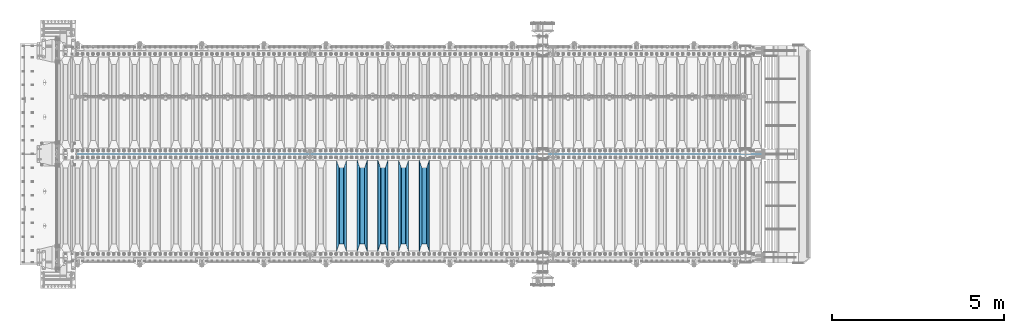
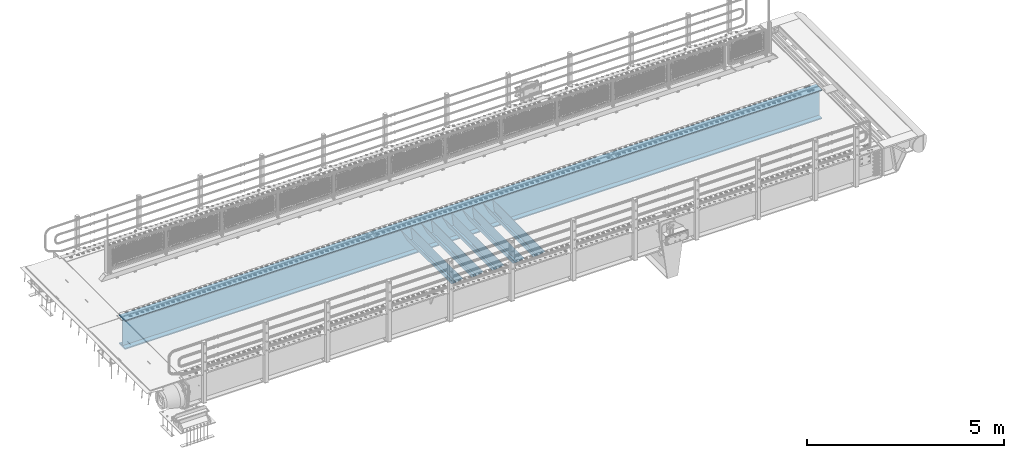
# One storey, part 119 of 242: 6 beams.
"""IFC2X3 building model written with IfcOpenShell, lengths in millimetres."""

from ifc_helpers import new_model, si_unit, frame, origin_with_axes, place, context, subcontext, project, spatial, faceted_brep, material, type_object, element, save


model = new_model("IFC2X3")

# Units and contexts
model_context = context("Model", 3, precision=1e-05, world=origin_with_axes())
body_context = subcontext(model_context, "Body", "Model", "MODEL_VIEW")
ifc_project = project(units=[si_unit("LENGTHUNIT", "METRE", prefix="MILLI"), si_unit("AREAUNIT", "SQUARE_METRE"), si_unit("VOLUMEUNIT", "CUBIC_METRE"), si_unit("MASSUNIT", "GRAM", prefix="KILO"), si_unit("TIMEUNIT", "SECOND"), si_unit("PLANEANGLEUNIT", "RADIAN"), si_unit("SOLIDANGLEUNIT", "STERADIAN"), si_unit("THERMODYNAMICTEMPERATUREUNIT", "DEGREE_CELSIUS"), si_unit("LUMINOUSINTENSITYUNIT", "LUMEN")], contexts=[model_context])

# Site, building, storey
site_placement = place(None, origin_with_axes())
site = spatial("IfcSite", under=ifc_project, at=site_placement, CompositionType="ELEMENT")
building_placement = place(site_placement, origin_with_axes())
building = spatial("IfcBuilding", under=site, at=building_placement, Name="Standard", CompositionType="ELEMENT")
storey_placement = place(building_placement, origin_with_axes())
storey = spatial("IfcBuildingStorey", under=building, at=storey_placement, Name="Undefined", CompositionType="ELEMENT", Elevation=0.0)

# Beams
ifc_material = material(Name="STEEL/S355N")
beam_type_1 = type_object("IfcBeamType", PredefinedType="NOTDEFINED")
beam_1_placement = place(storey_placement, frame((-31850.0, -23825.0, -115.0), z_axis=(0.0, 0.0, 1.0), x_axis=(0.0, 1.0, 0.0)))
element("IfcBeam", 1, at=beam_1_placement, inside=storey, type_object=beam_type_1, material=ifc_material, context=body_context, shape_type="Brep", body=[
    faceted_brep([(0.0, 150.0, 115.0), (0.0, 143.689999999999, 115.0), (2650.00000000297, 143.689999999999, 115.0), (2650.00000000297, 150.0, 115.0), (2650.00000000297, 142.059565218402, 110.000000003099), (2650.00000000297, 148.369565218403, 110.000000003099), (2441.90079219209, -80.1103600731112, -98.0992078077845), (2437.7588105432, -77.5672621345584, -102.241189456673), (2434.06523489747, -74.4080125315522, -105.934765102404), (2430.91086095089, -70.710272125576, -109.089139048974), (2428.37322971128, -66.5649389910068, -111.626770288588), (2426.51472138055, -62.0739139532889, -113.485278619323), (2425.38102192092, -57.3475956567672, -114.618978078955), (2424.99999999987, -52.5021667386536, -115.0), (2424.99999999987, 52.5021667386536, -115.0), (2425.38102192092, 57.3475956567672, -114.618978078955), (2426.51472138055, 62.0739139532889, -113.485278619323), (2428.37322971128, 66.5649389910068, -111.626770288588), (2430.91086095089, 70.710272125576, -109.089139048974), (2434.06523489747, 74.4080125315522, -105.934765102404), (2437.7588105432, 77.5672621345584, -102.241189456673), (2441.90079219209, 80.1103600731112, -98.0992078077846), (2446.38936140511, 81.9747917625791, -93.6106385947584), (2448.2494850041, 76.2713538057251, -91.7505149957729), (2444.62967112262, 74.76777986261, -95.3703288772456), (2441.28936334126, 72.7168944282894, -98.710636658607), (2438.31067330438, 70.1691124903846, -101.689326695487), (2435.76682334747, 67.1870637758839, -104.233176652398), (2433.72034654133, 63.8440531834895, -106.279653458539), (2432.22154950042, 60.222258798236, -107.778450499454), (2431.30727574265, 56.4107117849089, -108.692724257221), (2430.99999999987, 52.5031078186876, -109.0), (2430.99999999987, -52.5031078186876, -109.0), (2431.30727574265, -56.4107117849089, -108.692724257221), (2432.22154950042, -60.222258798236, -107.778450499454), (2433.72034654133, -63.8440531834895, -106.279653458539), (2435.76682334747, -67.1870637758839, -104.233176652398), (2438.31067330438, -70.1691124903846, -101.689326695487), (2441.28936334126, -72.7168944282894, -98.7106366586071), (2444.62967112262, -74.76777986261, -95.3703288772457), (2448.2494850041, -76.2713538057251, -91.7505149957729), (2650.00000000297, -142.059565218402, 110.000000003099), (2650.00000000297, -148.369565218403, 110.000000003099), (2446.38936140511, -81.9747917625791, -93.6106385947584), (2650.00000000297, -143.689999999999, 115.0), (2650.00000000297, -150.0, 115.0), (0.0, -143.689999999999, 115.0), (0.0, -150.0, 115.0), (0.0, -148.369565218261, 110.000000002669), (203.610638597427, -81.9747917625791, -93.6106385947584), (208.099207810454, -80.1103600731112, -98.0992078077845), (212.241189459342, -77.5672621345584, -102.241189456673), (215.934765105074, -74.4080125315522, -105.934765102404), (219.089139051644, -70.710272125576, -109.089139048974), (221.626770291256, -66.5649389910068, -111.626770288588), (223.485278621993, -62.0739139532889, -113.485278619323), (224.618978081624, -57.3475956567672, -114.618978078955), (225.00000000267, -52.5021667386536, -115.0), (225.00000000267, 52.5021667386536, -115.0), (224.618978081624, 57.3475956567672, -114.618978078955), (223.485278621993, 62.0739139532889, -113.485278619323), (221.626770291256, 66.5649389910068, -111.626770288588), (219.089139051644, 70.710272125576, -109.089139048974), (215.934765105074, 74.4080125315522, -105.934765102404), (212.241189459342, 77.5672621345584, -102.241189456673), (208.099207810454, 80.1103600731112, -98.0992078077846), (203.610638597427, 81.9747917625791, -93.6106385947584), (0.0, 148.369565218261, 110.000000002669), (0.0, 142.05956521826, 110.000000002669), (201.750514998443, 76.2713538057251, -91.7505149957729), (205.370328879915, 74.76777986261, -95.3703288772456), (208.710636661275, 72.7168944282894, -98.710636658607), (211.689326698157, 70.1691124903846, -101.689326695487), (214.233176655067, 67.1870637758839, -104.233176652398), (216.279653461206, 63.8440531834895, -106.279653458539), (217.778450502123, 60.222258798236, -107.778450499454), (218.69272425989, 56.4107117849089, -108.692724257221), (219.00000000267, 52.5031078186876, -109.0), (219.00000000267, -52.5031078186876, -109.0), (218.69272425989, -56.4107117849089, -108.692724257221), (217.778450502123, -60.222258798236, -107.778450499454), (216.279653461206, -63.8440531834895, -106.279653458539), (214.233176655067, -67.1870637758839, -104.233176652398), (211.689326698157, -70.1691124903846, -101.689326695487), (208.710636661275, -72.7168944282894, -98.7106366586071), (205.370328879915, -74.76777986261, -95.3703288772457), (201.750514998443, -76.2713538057251, -91.7505149957729), (0.0, -142.05956521826, 110.000000002669)], [[[0, 1, 2, 3]], [[3, 2, 4, 5]], [[6, 7, 8, 9, 10, 11, 12, 13, 14, 15, 16, 17, 18, 19, 20, 21, 22, 5, 4, 23, 24, 25, 26, 27, 28, 29, 30, 31, 32, 33, 34, 35, 36, 37, 38, 39, 40, 41, 42, 43]], [[44, 45, 42, 41]], [[46, 47, 45, 44]], [[43, 42, 45, 47, 48, 49]], [[6, 43, 49, 50]], [[7, 6, 50, 51]], [[8, 7, 51, 52]], [[9, 8, 52, 53]], [[10, 9, 53, 54]], [[11, 10, 54, 55]], [[12, 11, 55, 56]], [[13, 12, 56, 57]], [[14, 13, 57, 58]], [[15, 14, 58, 59]], [[16, 15, 59, 60]], [[17, 16, 60, 61]], [[18, 17, 61, 62]], [[19, 18, 62, 63]], [[20, 19, 63, 64]], [[21, 20, 64, 65]], [[22, 21, 65, 66]], [[0, 3, 5, 22, 66, 67]], [[1, 0, 67, 68]], [[23, 4, 2, 1, 68, 69]], [[24, 23, 69, 70]], [[25, 24, 70, 71]], [[26, 25, 71, 72]], [[27, 26, 72, 73]], [[28, 27, 73, 74]], [[29, 28, 74, 75]], [[30, 29, 75, 76]], [[31, 30, 76, 77]], [[32, 31, 77, 78]], [[33, 32, 78, 79]], [[34, 33, 79, 80]], [[35, 34, 80, 81]], [[36, 35, 81, 82]], [[37, 36, 82, 83]], [[38, 37, 83, 84]], [[39, 38, 84, 85]], [[40, 39, 85, 86]], [[46, 44, 41, 40, 86, 87]], [[47, 46, 87, 48]], [[86, 85, 84, 83, 82, 81, 80, 79, 78, 77, 76, 75, 74, 73, 72, 71, 70, 69, 68, 67, 66, 65, 64, 63, 62, 61, 60, 59, 58, 57, 56, 55, 54, 53, 52, 51, 50, 49, 48, 87]]]),
])
beam_2_placement = place(storey_placement, frame((-32450.0, -23825.0, -115.0), z_axis=(0.0, 0.0, 1.0), x_axis=(0.0, 1.0, 0.0)))
element("IfcBeam", 2, at=beam_2_placement, inside=storey, type_object=beam_type_1, material=ifc_material, context=body_context, shape_type="Brep", body=[
    faceted_brep([(0.0, 150.0, 115.0), (0.0, 143.689999999999, 115.0), (2650.00000000297, 143.689999999999, 115.0), (2650.00000000297, 150.0, 115.0), (2650.00000000297, 142.059565218402, 110.000000003099), (2650.00000000297, 148.369565218403, 110.000000003099), (2441.90079219209, -80.1103600731112, -98.0992078077845), (2437.7588105432, -77.5672621345584, -102.241189456673), (2434.06523489747, -74.4080125315522, -105.934765102404), (2430.91086095089, -70.710272125576, -109.089139048974), (2428.37322971128, -66.5649389910068, -111.626770288588), (2426.51472138055, -62.0739139532889, -113.485278619323), (2425.38102192092, -57.3475956567672, -114.618978078955), (2424.99999999987, -52.5021667386536, -115.0), (2424.99999999987, 52.5021667386536, -115.0), (2425.38102192092, 57.3475956567672, -114.618978078955), (2426.51472138055, 62.0739139532889, -113.485278619323), (2428.37322971128, 66.5649389910068, -111.626770288588), (2430.91086095089, 70.710272125576, -109.089139048974), (2434.06523489747, 74.4080125315522, -105.934765102404), (2437.7588105432, 77.5672621345584, -102.241189456673), (2441.90079219209, 80.1103600731112, -98.0992078077846), (2446.38936140511, 81.9747917625791, -93.6106385947584), (2448.2494850041, 76.2713538057251, -91.7505149957729), (2444.62967112262, 74.76777986261, -95.3703288772456), (2441.28936334126, 72.7168944282894, -98.710636658607), (2438.31067330438, 70.1691124903846, -101.689326695487), (2435.76682334747, 67.1870637758839, -104.233176652398), (2433.72034654133, 63.8440531834895, -106.279653458539), (2432.22154950042, 60.222258798236, -107.778450499454), (2431.30727574265, 56.4107117849089, -108.692724257221), (2430.99999999987, 52.5031078186876, -109.0), (2430.99999999987, -52.5031078186876, -109.0), (2431.30727574265, -56.4107117849089, -108.692724257221), (2432.22154950042, -60.222258798236, -107.778450499454), (2433.72034654133, -63.8440531834895, -106.279653458539), (2435.76682334747, -67.1870637758839, -104.233176652398), (2438.31067330438, -70.1691124903846, -101.689326695487), (2441.28936334126, -72.7168944282894, -98.7106366586071), (2444.62967112262, -74.76777986261, -95.3703288772457), (2448.2494850041, -76.2713538057251, -91.7505149957729), (2650.00000000297, -142.059565218402, 110.000000003099), (2650.00000000297, -148.369565218403, 110.000000003099), (2446.38936140511, -81.9747917625791, -93.6106385947584), (2650.00000000297, -143.689999999999, 115.0), (2650.00000000297, -150.0, 115.0), (0.0, -143.689999999999, 115.0), (0.0, -150.0, 115.0), (0.0, -148.369565218261, 110.000000002669), (203.610638597427, -81.9747917625791, -93.6106385947584), (208.099207810454, -80.1103600731112, -98.0992078077845), (212.241189459342, -77.5672621345584, -102.241189456673), (215.934765105074, -74.4080125315522, -105.934765102404), (219.089139051644, -70.710272125576, -109.089139048974), (221.626770291256, -66.5649389910068, -111.626770288588), (223.485278621993, -62.0739139532889, -113.485278619323), (224.618978081624, -57.3475956567672, -114.618978078955), (225.00000000267, -52.5021667386536, -115.0), (225.00000000267, 52.5021667386536, -115.0), (224.618978081624, 57.3475956567672, -114.618978078955), (223.485278621993, 62.0739139532889, -113.485278619323), (221.626770291256, 66.5649389910068, -111.626770288588), (219.089139051644, 70.710272125576, -109.089139048974), (215.934765105074, 74.4080125315522, -105.934765102404), (212.241189459342, 77.5672621345584, -102.241189456673), (208.099207810454, 80.1103600731112, -98.0992078077846), (203.610638597427, 81.9747917625791, -93.6106385947584), (0.0, 148.369565218261, 110.000000002669), (0.0, 142.05956521826, 110.000000002669), (201.750514998443, 76.2713538057251, -91.7505149957729), (205.370328879915, 74.76777986261, -95.3703288772456), (208.710636661275, 72.7168944282894, -98.710636658607), (211.689326698157, 70.1691124903846, -101.689326695487), (214.233176655067, 67.1870637758839, -104.233176652398), (216.279653461206, 63.8440531834895, -106.279653458539), (217.778450502123, 60.222258798236, -107.778450499454), (218.69272425989, 56.4107117849089, -108.692724257221), (219.00000000267, 52.5031078186876, -109.0), (219.00000000267, -52.5031078186876, -109.0), (218.69272425989, -56.4107117849089, -108.692724257221), (217.778450502123, -60.222258798236, -107.778450499454), (216.279653461206, -63.8440531834895, -106.279653458539), (214.233176655067, -67.1870637758839, -104.233176652398), (211.689326698157, -70.1691124903846, -101.689326695487), (208.710636661275, -72.7168944282894, -98.7106366586071), (205.370328879915, -74.76777986261, -95.3703288772457), (201.750514998443, -76.2713538057251, -91.7505149957729), (0.0, -142.05956521826, 110.000000002669)], [[[0, 1, 2, 3]], [[3, 2, 4, 5]], [[6, 7, 8, 9, 10, 11, 12, 13, 14, 15, 16, 17, 18, 19, 20, 21, 22, 5, 4, 23, 24, 25, 26, 27, 28, 29, 30, 31, 32, 33, 34, 35, 36, 37, 38, 39, 40, 41, 42, 43]], [[44, 45, 42, 41]], [[46, 47, 45, 44]], [[43, 42, 45, 47, 48, 49]], [[6, 43, 49, 50]], [[7, 6, 50, 51]], [[8, 7, 51, 52]], [[9, 8, 52, 53]], [[10, 9, 53, 54]], [[11, 10, 54, 55]], [[12, 11, 55, 56]], [[13, 12, 56, 57]], [[14, 13, 57, 58]], [[15, 14, 58, 59]], [[16, 15, 59, 60]], [[17, 16, 60, 61]], [[18, 17, 61, 62]], [[19, 18, 62, 63]], [[20, 19, 63, 64]], [[21, 20, 64, 65]], [[22, 21, 65, 66]], [[0, 3, 5, 22, 66, 67]], [[1, 0, 67, 68]], [[23, 4, 2, 1, 68, 69]], [[24, 23, 69, 70]], [[25, 24, 70, 71]], [[26, 25, 71, 72]], [[27, 26, 72, 73]], [[28, 27, 73, 74]], [[29, 28, 74, 75]], [[30, 29, 75, 76]], [[31, 30, 76, 77]], [[32, 31, 77, 78]], [[33, 32, 78, 79]], [[34, 33, 79, 80]], [[35, 34, 80, 81]], [[36, 35, 81, 82]], [[37, 36, 82, 83]], [[38, 37, 83, 84]], [[39, 38, 84, 85]], [[40, 39, 85, 86]], [[46, 44, 41, 40, 86, 87]], [[47, 46, 87, 48]], [[86, 85, 84, 83, 82, 81, 80, 79, 78, 77, 76, 75, 74, 73, 72, 71, 70, 69, 68, 67, 66, 65, 64, 63, 62, 61, 60, 59, 58, 57, 56, 55, 54, 53, 52, 51, 50, 49, 48, 87]]]),
])
beam_3_placement = place(storey_placement, frame((-33050.0, -23825.0, -115.0), z_axis=(0.0, 0.0, 1.0), x_axis=(0.0, 1.0, 0.0)))
element("IfcBeam", 3, at=beam_3_placement, inside=storey, type_object=beam_type_1, material=ifc_material, context=body_context, shape_type="Brep", body=[
    faceted_brep([(0.0, 150.0, 115.0), (0.0, 143.689999999999, 115.0), (2650.00000000297, 143.689999999999, 115.0), (2650.00000000297, 150.0, 115.0), (2650.00000000297, 142.059565218402, 110.000000003099), (2650.00000000297, 148.369565218403, 110.000000003099), (2441.90079219209, -80.1103600731112, -98.0992078077845), (2437.7588105432, -77.5672621345584, -102.241189456673), (2434.06523489747, -74.4080125315522, -105.934765102404), (2430.91086095089, -70.710272125576, -109.089139048974), (2428.37322971128, -66.5649389910068, -111.626770288588), (2426.51472138055, -62.0739139532889, -113.485278619323), (2425.38102192092, -57.3475956567672, -114.618978078955), (2424.99999999987, -52.5021667386536, -115.0), (2424.99999999987, 52.5021667386536, -115.0), (2425.38102192092, 57.3475956567672, -114.618978078955), (2426.51472138055, 62.0739139532889, -113.485278619323), (2428.37322971128, 66.5649389910068, -111.626770288588), (2430.91086095089, 70.710272125576, -109.089139048974), (2434.06523489747, 74.4080125315522, -105.934765102404), (2437.7588105432, 77.5672621345584, -102.241189456673), (2441.90079219209, 80.1103600731112, -98.0992078077846), (2446.38936140511, 81.9747917625791, -93.6106385947584), (2448.2494850041, 76.2713538057251, -91.7505149957729), (2444.62967112262, 74.76777986261, -95.3703288772456), (2441.28936334126, 72.7168944282894, -98.710636658607), (2438.31067330438, 70.1691124903846, -101.689326695487), (2435.76682334747, 67.1870637758839, -104.233176652398), (2433.72034654133, 63.8440531834895, -106.279653458539), (2432.22154950042, 60.222258798236, -107.778450499454), (2431.30727574265, 56.4107117849089, -108.692724257221), (2430.99999999987, 52.5031078186876, -109.0), (2430.99999999987, -52.5031078186876, -109.0), (2431.30727574265, -56.4107117849089, -108.692724257221), (2432.22154950042, -60.222258798236, -107.778450499454), (2433.72034654133, -63.8440531834895, -106.279653458539), (2435.76682334747, -67.1870637758839, -104.233176652398), (2438.31067330438, -70.1691124903846, -101.689326695487), (2441.28936334126, -72.7168944282894, -98.7106366586071), (2444.62967112262, -74.76777986261, -95.3703288772457), (2448.2494850041, -76.2713538057251, -91.7505149957729), (2650.00000000297, -142.059565218402, 110.000000003099), (2650.00000000297, -148.369565218403, 110.000000003099), (2446.38936140511, -81.9747917625791, -93.6106385947584), (2650.00000000297, -143.689999999999, 115.0), (2650.00000000297, -150.0, 115.0), (0.0, -143.689999999999, 115.0), (0.0, -150.0, 115.0), (0.0, -148.369565218261, 110.000000002669), (203.610638597427, -81.9747917625791, -93.6106385947584), (208.099207810454, -80.1103600731112, -98.0992078077845), (212.241189459342, -77.5672621345584, -102.241189456673), (215.934765105074, -74.4080125315522, -105.934765102404), (219.089139051644, -70.710272125576, -109.089139048974), (221.626770291256, -66.5649389910068, -111.626770288588), (223.485278621993, -62.0739139532889, -113.485278619323), (224.618978081624, -57.3475956567672, -114.618978078955), (225.00000000267, -52.5021667386536, -115.0), (225.00000000267, 52.5021667386536, -115.0), (224.618978081624, 57.3475956567672, -114.618978078955), (223.485278621993, 62.0739139532889, -113.485278619323), (221.626770291256, 66.5649389910068, -111.626770288588), (219.089139051644, 70.710272125576, -109.089139048974), (215.934765105074, 74.4080125315522, -105.934765102404), (212.241189459342, 77.5672621345584, -102.241189456673), (208.099207810454, 80.1103600731112, -98.0992078077846), (203.610638597427, 81.9747917625791, -93.6106385947584), (0.0, 148.369565218261, 110.000000002669), (0.0, 142.05956521826, 110.000000002669), (201.750514998443, 76.2713538057251, -91.7505149957729), (205.370328879915, 74.76777986261, -95.3703288772456), (208.710636661275, 72.7168944282894, -98.710636658607), (211.689326698157, 70.1691124903846, -101.689326695487), (214.233176655067, 67.1870637758839, -104.233176652398), (216.279653461206, 63.8440531834895, -106.279653458539), (217.778450502123, 60.222258798236, -107.778450499454), (218.69272425989, 56.4107117849089, -108.692724257221), (219.00000000267, 52.5031078186876, -109.0), (219.00000000267, -52.5031078186876, -109.0), (218.69272425989, -56.4107117849089, -108.692724257221), (217.778450502123, -60.222258798236, -107.778450499454), (216.279653461206, -63.8440531834895, -106.279653458539), (214.233176655067, -67.1870637758839, -104.233176652398), (211.689326698157, -70.1691124903846, -101.689326695487), (208.710636661275, -72.7168944282894, -98.7106366586071), (205.370328879915, -74.76777986261, -95.3703288772457), (201.750514998443, -76.2713538057251, -91.7505149957729), (0.0, -142.05956521826, 110.000000002669)], [[[0, 1, 2, 3]], [[3, 2, 4, 5]], [[6, 7, 8, 9, 10, 11, 12, 13, 14, 15, 16, 17, 18, 19, 20, 21, 22, 5, 4, 23, 24, 25, 26, 27, 28, 29, 30, 31, 32, 33, 34, 35, 36, 37, 38, 39, 40, 41, 42, 43]], [[44, 45, 42, 41]], [[46, 47, 45, 44]], [[43, 42, 45, 47, 48, 49]], [[6, 43, 49, 50]], [[7, 6, 50, 51]], [[8, 7, 51, 52]], [[9, 8, 52, 53]], [[10, 9, 53, 54]], [[11, 10, 54, 55]], [[12, 11, 55, 56]], [[13, 12, 56, 57]], [[14, 13, 57, 58]], [[15, 14, 58, 59]], [[16, 15, 59, 60]], [[17, 16, 60, 61]], [[18, 17, 61, 62]], [[19, 18, 62, 63]], [[20, 19, 63, 64]], [[21, 20, 64, 65]], [[22, 21, 65, 66]], [[0, 3, 5, 22, 66, 67]], [[1, 0, 67, 68]], [[23, 4, 2, 1, 68, 69]], [[24, 23, 69, 70]], [[25, 24, 70, 71]], [[26, 25, 71, 72]], [[27, 26, 72, 73]], [[28, 27, 73, 74]], [[29, 28, 74, 75]], [[30, 29, 75, 76]], [[31, 30, 76, 77]], [[32, 31, 77, 78]], [[33, 32, 78, 79]], [[34, 33, 79, 80]], [[35, 34, 80, 81]], [[36, 35, 81, 82]], [[37, 36, 82, 83]], [[38, 37, 83, 84]], [[39, 38, 84, 85]], [[40, 39, 85, 86]], [[46, 44, 41, 40, 86, 87]], [[47, 46, 87, 48]], [[86, 85, 84, 83, 82, 81, 80, 79, 78, 77, 76, 75, 74, 73, 72, 71, 70, 69, 68, 67, 66, 65, 64, 63, 62, 61, 60, 59, 58, 57, 56, 55, 54, 53, 52, 51, 50, 49, 48, 87]]]),
])
beam_4_placement = place(storey_placement, frame((-33650.0, -23825.0, -115.0), z_axis=(0.0, 0.0, 1.0), x_axis=(0.0, 1.0, 0.0)))
element("IfcBeam", 4, at=beam_4_placement, inside=storey, type_object=beam_type_1, material=ifc_material, context=body_context, shape_type="Brep", body=[
    faceted_brep([(0.0, 150.0, 115.0), (0.0, 143.689999999999, 115.0), (2650.00000000297, 143.689999999999, 115.0), (2650.00000000297, 150.0, 115.0), (2650.00000000297, 142.059565218402, 110.000000003099), (2650.00000000297, 148.369565218403, 110.000000003099), (2441.90079219209, -80.1103600731112, -98.0992078077845), (2437.7588105432, -77.5672621345584, -102.241189456673), (2434.06523489747, -74.4080125315522, -105.934765102404), (2430.91086095089, -70.710272125576, -109.089139048974), (2428.37322971128, -66.5649389910068, -111.626770288588), (2426.51472138055, -62.0739139532889, -113.485278619323), (2425.38102192092, -57.3475956567672, -114.618978078955), (2424.99999999987, -52.5021667386536, -115.0), (2424.99999999987, 52.5021667386536, -115.0), (2425.38102192092, 57.3475956567672, -114.618978078955), (2426.51472138055, 62.0739139532889, -113.485278619323), (2428.37322971128, 66.5649389910068, -111.626770288588), (2430.91086095089, 70.710272125576, -109.089139048974), (2434.06523489747, 74.4080125315522, -105.934765102404), (2437.7588105432, 77.5672621345584, -102.241189456673), (2441.90079219209, 80.1103600731112, -98.0992078077846), (2446.38936140511, 81.9747917625791, -93.6106385947584), (2448.2494850041, 76.2713538057251, -91.7505149957729), (2444.62967112262, 74.76777986261, -95.3703288772456), (2441.28936334126, 72.7168944282894, -98.710636658607), (2438.31067330438, 70.1691124903846, -101.689326695487), (2435.76682334747, 67.1870637758839, -104.233176652398), (2433.72034654133, 63.8440531834895, -106.279653458539), (2432.22154950042, 60.222258798236, -107.778450499454), (2431.30727574265, 56.4107117849089, -108.692724257221), (2430.99999999987, 52.5031078186876, -109.0), (2430.99999999987, -52.5031078186876, -109.0), (2431.30727574265, -56.4107117849089, -108.692724257221), (2432.22154950042, -60.222258798236, -107.778450499454), (2433.72034654133, -63.8440531834895, -106.279653458539), (2435.76682334747, -67.1870637758839, -104.233176652398), (2438.31067330438, -70.1691124903846, -101.689326695487), (2441.28936334126, -72.7168944282894, -98.7106366586071), (2444.62967112262, -74.76777986261, -95.3703288772457), (2448.2494850041, -76.2713538057251, -91.7505149957729), (2650.00000000297, -142.059565218402, 110.000000003099), (2650.00000000297, -148.369565218403, 110.000000003099), (2446.38936140511, -81.9747917625791, -93.6106385947584), (2650.00000000297, -143.689999999999, 115.0), (2650.00000000297, -150.0, 115.0), (0.0, -143.689999999999, 115.0), (0.0, -150.0, 115.0), (0.0, -148.369565218261, 110.000000002669), (203.610638597427, -81.9747917625791, -93.6106385947584), (208.099207810454, -80.1103600731112, -98.0992078077845), (212.241189459342, -77.5672621345584, -102.241189456673), (215.934765105074, -74.4080125315522, -105.934765102404), (219.089139051644, -70.710272125576, -109.089139048974), (221.626770291256, -66.5649389910068, -111.626770288588), (223.485278621993, -62.0739139532889, -113.485278619323), (224.618978081624, -57.3475956567672, -114.618978078955), (225.00000000267, -52.5021667386536, -115.0), (225.00000000267, 52.5021667386536, -115.0), (224.618978081624, 57.3475956567672, -114.618978078955), (223.485278621993, 62.0739139532889, -113.485278619323), (221.626770291256, 66.5649389910068, -111.626770288588), (219.089139051644, 70.710272125576, -109.089139048974), (215.934765105074, 74.4080125315522, -105.934765102404), (212.241189459342, 77.5672621345584, -102.241189456673), (208.099207810454, 80.1103600731112, -98.0992078077846), (203.610638597427, 81.9747917625791, -93.6106385947584), (0.0, 148.369565218261, 110.000000002669), (0.0, 142.05956521826, 110.000000002669), (201.750514998443, 76.2713538057251, -91.7505149957729), (205.370328879915, 74.76777986261, -95.3703288772456), (208.710636661275, 72.7168944282894, -98.710636658607), (211.689326698157, 70.1691124903846, -101.689326695487), (214.233176655067, 67.1870637758839, -104.233176652398), (216.279653461206, 63.8440531834895, -106.279653458539), (217.778450502123, 60.222258798236, -107.778450499454), (218.69272425989, 56.4107117849089, -108.692724257221), (219.00000000267, 52.5031078186876, -109.0), (219.00000000267, -52.5031078186876, -109.0), (218.69272425989, -56.4107117849089, -108.692724257221), (217.778450502123, -60.222258798236, -107.778450499454), (216.279653461206, -63.8440531834895, -106.279653458539), (214.233176655067, -67.1870637758839, -104.233176652398), (211.689326698157, -70.1691124903846, -101.689326695487), (208.710636661275, -72.7168944282894, -98.7106366586071), (205.370328879915, -74.76777986261, -95.3703288772457), (201.750514998443, -76.2713538057251, -91.7505149957729), (0.0, -142.05956521826, 110.000000002669)], [[[0, 1, 2, 3]], [[3, 2, 4, 5]], [[6, 7, 8, 9, 10, 11, 12, 13, 14, 15, 16, 17, 18, 19, 20, 21, 22, 5, 4, 23, 24, 25, 26, 27, 28, 29, 30, 31, 32, 33, 34, 35, 36, 37, 38, 39, 40, 41, 42, 43]], [[44, 45, 42, 41]], [[46, 47, 45, 44]], [[43, 42, 45, 47, 48, 49]], [[6, 43, 49, 50]], [[7, 6, 50, 51]], [[8, 7, 51, 52]], [[9, 8, 52, 53]], [[10, 9, 53, 54]], [[11, 10, 54, 55]], [[12, 11, 55, 56]], [[13, 12, 56, 57]], [[14, 13, 57, 58]], [[15, 14, 58, 59]], [[16, 15, 59, 60]], [[17, 16, 60, 61]], [[18, 17, 61, 62]], [[19, 18, 62, 63]], [[20, 19, 63, 64]], [[21, 20, 64, 65]], [[22, 21, 65, 66]], [[0, 3, 5, 22, 66, 67]], [[1, 0, 67, 68]], [[23, 4, 2, 1, 68, 69]], [[24, 23, 69, 70]], [[25, 24, 70, 71]], [[26, 25, 71, 72]], [[27, 26, 72, 73]], [[28, 27, 73, 74]], [[29, 28, 74, 75]], [[30, 29, 75, 76]], [[31, 30, 76, 77]], [[32, 31, 77, 78]], [[33, 32, 78, 79]], [[34, 33, 79, 80]], [[35, 34, 80, 81]], [[36, 35, 81, 82]], [[37, 36, 82, 83]], [[38, 37, 83, 84]], [[39, 38, 84, 85]], [[40, 39, 85, 86]], [[46, 44, 41, 40, 86, 87]], [[47, 46, 87, 48]], [[86, 85, 84, 83, 82, 81, 80, 79, 78, 77, 76, 75, 74, 73, 72, 71, 70, 69, 68, 67, 66, 65, 64, 63, 62, 61, 60, 59, 58, 57, 56, 55, 54, 53, 52, 51, 50, 49, 48, 87]]]),
])
beam_5_placement = place(storey_placement, frame((-34250.0, -23825.0, -115.0), z_axis=(0.0, 0.0, 1.0), x_axis=(0.0, 1.0, 0.0)))
element("IfcBeam", 5, at=beam_5_placement, inside=storey, type_object=beam_type_1, material=ifc_material, context=body_context, shape_type="Brep", body=[
    faceted_brep([(0.0, 150.0, 115.0), (0.0, 143.689999999999, 115.0), (2650.00000000297, 143.689999999999, 115.0), (2650.00000000297, 150.0, 115.0), (2650.00000000297, 142.059565218402, 110.000000003099), (2650.00000000297, 148.369565218403, 110.000000003099), (2441.90079219209, -80.1103600731112, -98.0992078077845), (2437.7588105432, -77.5672621345584, -102.241189456673), (2434.06523489747, -74.4080125315522, -105.934765102404), (2430.91086095089, -70.710272125576, -109.089139048974), (2428.37322971128, -66.5649389910068, -111.626770288588), (2426.51472138055, -62.0739139532889, -113.485278619323), (2425.38102192092, -57.3475956567672, -114.618978078955), (2424.99999999987, -52.5021667386536, -115.0), (2424.99999999987, 52.5021667386536, -115.0), (2425.38102192092, 57.3475956567672, -114.618978078955), (2426.51472138055, 62.0739139532889, -113.485278619323), (2428.37322971128, 66.5649389910068, -111.626770288588), (2430.91086095089, 70.710272125576, -109.089139048974), (2434.06523489747, 74.4080125315522, -105.934765102404), (2437.7588105432, 77.5672621345584, -102.241189456673), (2441.90079219209, 80.1103600731112, -98.0992078077846), (2446.38936140511, 81.9747917625791, -93.6106385947584), (2448.2494850041, 76.2713538057251, -91.7505149957729), (2444.62967112262, 74.76777986261, -95.3703288772456), (2441.28936334126, 72.7168944282894, -98.710636658607), (2438.31067330438, 70.1691124903846, -101.689326695487), (2435.76682334747, 67.1870637758839, -104.233176652398), (2433.72034654133, 63.8440531834895, -106.279653458539), (2432.22154950042, 60.222258798236, -107.778450499454), (2431.30727574265, 56.4107117849089, -108.692724257221), (2430.99999999987, 52.5031078186876, -109.0), (2430.99999999987, -52.5031078186876, -109.0), (2431.30727574265, -56.4107117849089, -108.692724257221), (2432.22154950042, -60.222258798236, -107.778450499454), (2433.72034654133, -63.8440531834895, -106.279653458539), (2435.76682334747, -67.1870637758839, -104.233176652398), (2438.31067330438, -70.1691124903846, -101.689326695487), (2441.28936334126, -72.7168944282894, -98.7106366586071), (2444.62967112262, -74.76777986261, -95.3703288772457), (2448.2494850041, -76.2713538057251, -91.7505149957729), (2650.00000000297, -142.059565218402, 110.000000003099), (2650.00000000297, -148.369565218403, 110.000000003099), (2446.38936140511, -81.9747917625791, -93.6106385947584), (2650.00000000297, -143.689999999999, 115.0), (2650.00000000297, -150.0, 115.0), (0.0, -143.689999999999, 115.0), (0.0, -150.0, 115.0), (0.0, -148.369565218261, 110.000000002669), (203.610638597427, -81.9747917625791, -93.6106385947584), (208.099207810454, -80.1103600731112, -98.0992078077845), (212.241189459342, -77.5672621345584, -102.241189456673), (215.934765105074, -74.4080125315522, -105.934765102404), (219.089139051644, -70.710272125576, -109.089139048974), (221.626770291256, -66.5649389910068, -111.626770288588), (223.485278621993, -62.0739139532889, -113.485278619323), (224.618978081624, -57.3475956567672, -114.618978078955), (225.00000000267, -52.5021667386536, -115.0), (225.00000000267, 52.5021667386536, -115.0), (224.618978081624, 57.3475956567672, -114.618978078955), (223.485278621993, 62.0739139532889, -113.485278619323), (221.626770291256, 66.5649389910068, -111.626770288588), (219.089139051644, 70.710272125576, -109.089139048974), (215.934765105074, 74.4080125315522, -105.934765102404), (212.241189459342, 77.5672621345584, -102.241189456673), (208.099207810454, 80.1103600731112, -98.0992078077846), (203.610638597427, 81.9747917625791, -93.6106385947584), (0.0, 148.369565218261, 110.000000002669), (0.0, 142.05956521826, 110.000000002669), (201.750514998443, 76.2713538057251, -91.7505149957729), (205.370328879915, 74.76777986261, -95.3703288772456), (208.710636661275, 72.7168944282894, -98.710636658607), (211.689326698157, 70.1691124903846, -101.689326695487), (214.233176655067, 67.1870637758839, -104.233176652398), (216.279653461206, 63.8440531834895, -106.279653458539), (217.778450502123, 60.222258798236, -107.778450499454), (218.69272425989, 56.4107117849089, -108.692724257221), (219.00000000267, 52.5031078186876, -109.0), (219.00000000267, -52.5031078186876, -109.0), (218.69272425989, -56.4107117849089, -108.692724257221), (217.778450502123, -60.222258798236, -107.778450499454), (216.279653461206, -63.8440531834895, -106.279653458539), (214.233176655067, -67.1870637758839, -104.233176652398), (211.689326698157, -70.1691124903846, -101.689326695487), (208.710636661275, -72.7168944282894, -98.7106366586071), (205.370328879915, -74.76777986261, -95.3703288772457), (201.750514998443, -76.2713538057251, -91.7505149957729), (0.0, -142.05956521826, 110.000000002669)], [[[0, 1, 2, 3]], [[3, 2, 4, 5]], [[6, 7, 8, 9, 10, 11, 12, 13, 14, 15, 16, 17, 18, 19, 20, 21, 22, 5, 4, 23, 24, 25, 26, 27, 28, 29, 30, 31, 32, 33, 34, 35, 36, 37, 38, 39, 40, 41, 42, 43]], [[44, 45, 42, 41]], [[46, 47, 45, 44]], [[43, 42, 45, 47, 48, 49]], [[6, 43, 49, 50]], [[7, 6, 50, 51]], [[8, 7, 51, 52]], [[9, 8, 52, 53]], [[10, 9, 53, 54]], [[11, 10, 54, 55]], [[12, 11, 55, 56]], [[13, 12, 56, 57]], [[14, 13, 57, 58]], [[15, 14, 58, 59]], [[16, 15, 59, 60]], [[17, 16, 60, 61]], [[18, 17, 61, 62]], [[19, 18, 62, 63]], [[20, 19, 63, 64]], [[21, 20, 64, 65]], [[22, 21, 65, 66]], [[0, 3, 5, 22, 66, 67]], [[1, 0, 67, 68]], [[23, 4, 2, 1, 68, 69]], [[24, 23, 69, 70]], [[25, 24, 70, 71]], [[26, 25, 71, 72]], [[27, 26, 72, 73]], [[28, 27, 73, 74]], [[29, 28, 74, 75]], [[30, 29, 75, 76]], [[31, 30, 76, 77]], [[32, 31, 77, 78]], [[33, 32, 78, 79]], [[34, 33, 79, 80]], [[35, 34, 80, 81]], [[36, 35, 81, 82]], [[37, 36, 82, 83]], [[38, 37, 83, 84]], [[39, 38, 84, 85]], [[40, 39, 85, 86]], [[46, 44, 41, 40, 86, 87]], [[47, 46, 87, 48]], [[86, 85, 84, 83, 82, 81, 80, 79, 78, 77, 76, 75, 74, 73, 72, 71, 70, 69, 68, 67, 66, 65, 64, 63, 62, 61, 60, 59, 58, 57, 56, 55, 54, 53, 52, 51, 50, 49, 48, 87]]]),
])
beam_type_2 = type_object("IfcBeamType", Name="HEB900", PredefinedType="NOTDEFINED")
beam_6_placement = place(storey_placement, frame((-42440.0, -21000.0, -450.0), z_axis=(0.0, 0.0, 1.0), x_axis=(1.0, 0.0, 0.0)))
element("IfcBeam", 6, at=beam_6_placement, inside=storey, type_object=beam_type_2, material=ifc_material, ObjectType="HEB900", context=body_context, shape_type="Brep", body=[
    faceted_brep([(0.0, 150.0, -450.0), (0.0, 150.0, -415.0), (20380.0, 150.0, -415.0), (20380.0, 150.0, -450.0), (0.0, 9.25, -415.0), (20380.0, 9.25, -415.0), (0.0, 9.25, 415.0), (20380.0, 9.25, 415.0), (0.0, 150.0, 415.0), (20380.0, 150.0, 415.0), (0.0, 150.0, 450.0), (20380.0, 150.0, 450.0), (0.0, -150.0, 450.0), (20380.0, -150.0, 450.0), (0.0, -150.0, 415.0), (20380.0, -150.0, 415.0), (0.0, -9.25, 415.0), (20380.0, -9.25, 415.0), (0.0, -9.25, -415.0), (20380.0, -9.25, -415.0), (0.0, -150.0, -415.0), (20380.0, -150.0, -415.0), (0.0, -150.0, -450.0), (20380.0, -150.0, -450.0)], [[[0, 1, 2, 3]], [[1, 4, 5, 2]], [[4, 6, 7, 5]], [[6, 8, 9, 7]], [[8, 10, 11, 9]], [[10, 12, 13, 11]], [[12, 14, 15, 13]], [[14, 16, 17, 15]], [[16, 18, 19, 17]], [[18, 20, 21, 19]], [[20, 22, 23, 21]], [[22, 0, 3, 23]], [[5, 7, 9, 11, 13, 15, 17, 19, 21, 23, 3, 2]], [[22, 20, 18, 16, 14, 12, 10, 8, 6, 4, 1, 0]]]),
])

save(model, "model.ifc")
